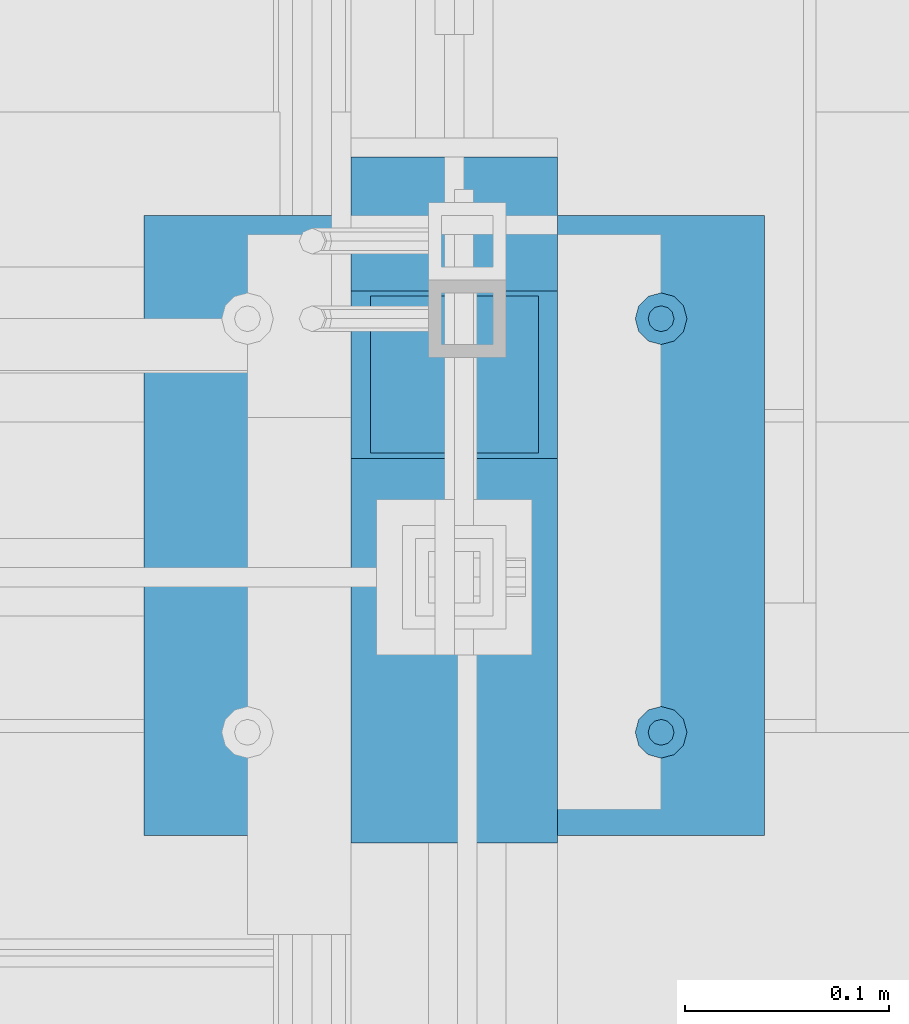
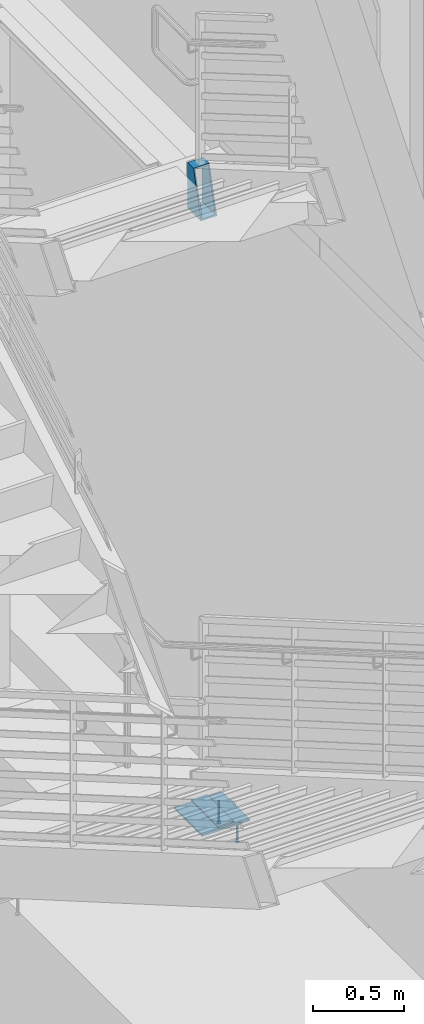
# One storey, part 875 of 1179: 5 beams, 3 elements without a shape of their own.
"""IFC2X3 building model written with IfcOpenShell, lengths in millimetres."""

from ifc_helpers import new_model, si_unit, frame, origin_with_axes, place, context, subcontext, project, spatial, faceted_brep, material, type_object, element, aggregate, save


model = new_model("IFC2X3")

# Units and contexts
model_context = context("Model", 3, precision=1e-05, world=origin_with_axes())
body_context = subcontext(model_context, "Body", "Model", "MODEL_VIEW")
ifc_project = project(units=[si_unit("LENGTHUNIT", "METRE", prefix="MILLI"), si_unit("AREAUNIT", "SQUARE_METRE"), si_unit("VOLUMEUNIT", "CUBIC_METRE"), si_unit("MASSUNIT", "GRAM", prefix="KILO"), si_unit("TIMEUNIT", "SECOND"), si_unit("PLANEANGLEUNIT", "RADIAN"), si_unit("SOLIDANGLEUNIT", "STERADIAN"), si_unit("THERMODYNAMICTEMPERATUREUNIT", "DEGREE_CELSIUS"), si_unit("LUMINOUSINTENSITYUNIT", "LUMEN")], contexts=[model_context])

# Site, building, storey
site_placement = place(None, origin_with_axes())
site = spatial("IfcSite", under=ifc_project, at=site_placement, CompositionType="ELEMENT")
building_placement = place(site_placement, origin_with_axes())
building = spatial("IfcBuilding", under=site, at=building_placement, Name="Undefined", CompositionType="ELEMENT")
storey_placement = place(building_placement, origin_with_axes())
storey = spatial("IfcBuildingStorey", under=building, at=storey_placement, Name="Undefined", CompositionType="ELEMENT", Elevation=0.0)

# Assembly, beams
assembly_1_placement = place(storey_placement, origin_with_axes())
assembly_1 = element("IfcElementAssembly", 1, at=assembly_1_placement, inside=storey, Name="EMBED", AssemblyPlace="NOTDEFINED", PredefinedType="RIGID_FRAME")
ifc_material_1 = material(Name="STEEL/A108")
beam_type_1 = type_object("IfcBeamType", Name="STUD_1/2-DIA", PredefinedType="NOTDEFINED")
beam_1_placement = place(assembly_1_placement, frame((-152.399999997227, 35242.5000000001, -12.6999996742202), z_axis=(0.0, 1.0, 0.0), x_axis=(0.0, 0.0, -1.0)))
beam_1 = element("IfcBeam", 2, at=beam_1_placement, type_object=beam_type_1, material=ifc_material_1, Name="STUD", ObjectType="STUD_1/2-DIA", context=body_context, shape_type="Brep", body=[
    faceted_brep([(0.0, -3.1800000667572, 5.5), (0.0, -5.5, 3.1800000667572), (141.732, -5.5, 3.1800000667572), (141.732, -3.1800000667572, 5.5), (0.0, -6.34999999999854, 0.0), (141.732, -6.34999990463257, 0.0), (0.0, -5.5, -3.1800000667572), (141.732, -5.5, -3.1800000667572), (0.0, -3.1800000667572, -5.5), (141.732, -3.1800000667572, -5.5), (0.0, 0.0, -6.34999999999991), (141.732, 0.0, -6.34999990463257), (0.0, 3.1800000667572, -5.5), (141.732, 3.1800000667572, -5.5), (0.0, 5.5, -3.1800000667572), (141.732, 5.5, -3.1800000667572), (0.0, 6.34999999999854, 0.0), (141.732, 6.34999990463257, 0.0), (0.0, 5.5, 3.1800000667572), (141.732, 5.5, 3.1800000667572), (0.0, 3.1800000667572, 5.5), (141.732, 3.1800000667572, 5.5), (0.0, 0.0, 6.34999999999991), (141.732, 0.0, 6.34999990463257), (144.78, -10.9899997711182, 6.34999990463257), (144.78, -6.34000015258789, 10.9899997711182), (144.78, -12.6999998092651, 0.0), (144.78, -10.9899997711182, -6.34999990463257), (144.78, -6.34000015258789, -10.9899997711182), (144.78, 0.0, -12.6899995803833), (144.78, 6.34000015258789, -10.9899997711182), (144.78, 10.9899997711182, -6.34999990463257), (144.78, 12.6999998092651, 0.0), (144.78, 10.9899997711182, 6.34999990463257), (144.78, 6.34000015258789, 10.9899997711182), (144.78, 0.0, 12.6899995803833), (152.4, -10.9899997711182, 6.34999990463257), (152.4, -6.34000015258789, 10.9899997711182), (152.4, -12.6999998092651, 0.0), (152.4, -10.9899997711182, -6.34999990463257), (152.4, -6.34000015258789, -10.9899997711182), (152.4, 0.0, -12.6899995803833), (152.4, 6.34000015258789, -10.9899997711182), (152.4, 10.9899997711182, -6.34999990463257), (152.4, 12.6999998092651, 0.0), (152.4, 10.9899997711182, 6.34999990463257), (152.4, 6.34000015258789, 10.9899997711182), (152.4, 0.0, 12.6899995803833)], [[[0, 1, 2, 3]], [[1, 4, 5, 2]], [[4, 6, 7, 5]], [[6, 8, 9, 7]], [[8, 10, 11, 9]], [[10, 12, 13, 11]], [[12, 14, 15, 13]], [[14, 16, 17, 15]], [[16, 18, 19, 17]], [[18, 20, 21, 19]], [[20, 22, 23, 21]], [[22, 0, 3, 23]], [[22, 20, 18, 16, 14, 12, 10, 8, 6, 4, 1, 0]], [[3, 2, 24, 25]], [[2, 5, 26, 24]], [[5, 7, 27, 26]], [[7, 9, 28, 27]], [[9, 11, 29, 28]], [[11, 13, 30, 29]], [[13, 15, 31, 30]], [[15, 17, 32, 31]], [[17, 19, 33, 32]], [[19, 21, 34, 33]], [[21, 23, 35, 34]], [[23, 3, 25, 35]], [[25, 24, 36, 37]], [[24, 26, 38, 36]], [[26, 27, 39, 38]], [[27, 28, 40, 39]], [[28, 29, 41, 40]], [[29, 30, 42, 41]], [[30, 31, 43, 42]], [[31, 32, 44, 43]], [[32, 33, 45, 44]], [[33, 34, 46, 45]], [[34, 35, 47, 46]], [[35, 25, 37, 47]], [[38, 39, 40, 41, 42, 43, 44, 45, 46, 47, 37, 36]]]),
])
beam_2_placement = place(assembly_1_placement, frame((-152.399999997227, 35039.3000000001, -12.6999996742202), z_axis=(0.0, 1.0, 0.0), x_axis=(0.0, 0.0, -1.0)))
beam_2 = element("IfcBeam", 3, at=beam_2_placement, type_object=beam_type_1, material=ifc_material_1, Name="STUD", ObjectType="STUD_1/2-DIA", context=body_context, shape_type="Brep", body=[
    faceted_brep([(0.0, -3.1800000667572, 5.5), (0.0, -5.5, 3.1800000667572), (141.732, -5.5, 3.1800000667572), (141.732, -3.1800000667572, 5.5), (0.0, -6.34999999999854, 0.0), (141.732, -6.34999990463257, 0.0), (0.0, -5.5, -3.1800000667572), (141.732, -5.5, -3.1800000667572), (0.0, -3.1800000667572, -5.5), (141.732, -3.1800000667572, -5.5), (0.0, 0.0, -6.34999999999991), (141.732, 0.0, -6.34999990463257), (0.0, 3.1800000667572, -5.5), (141.732, 3.1800000667572, -5.5), (0.0, 5.5, -3.1800000667572), (141.732, 5.5, -3.1800000667572), (0.0, 6.34999999999854, 0.0), (141.732, 6.34999990463257, 0.0), (0.0, 5.5, 3.1800000667572), (141.732, 5.5, 3.1800000667572), (0.0, 3.1800000667572, 5.5), (141.732, 3.1800000667572, 5.5), (0.0, 0.0, 6.34999999999991), (141.732, 0.0, 6.34999990463257), (144.78, -10.9899997711182, 6.34999990463257), (144.78, -6.34000015258789, 10.9899997711182), (144.78, -12.6999998092651, 0.0), (144.78, -10.9899997711182, -6.34999990463257), (144.78, -6.34000015258789, -10.9899997711182), (144.78, 0.0, -12.6899995803833), (144.78, 6.34000015258789, -10.9899997711182), (144.78, 10.9899997711182, -6.34999990463257), (144.78, 12.6999998092651, 0.0), (144.78, 10.9899997711182, 6.34999990463257), (144.78, 6.34000015258789, 10.9899997711182), (144.78, 0.0, 12.6899995803833), (152.4, -10.9899997711182, 6.34999990463257), (152.4, -6.34000015258789, 10.9899997711182), (152.4, -12.6999998092651, 0.0), (152.4, -10.9899997711182, -6.34999990463257), (152.4, -6.34000015258789, -10.9899997711182), (152.4, 0.0, -12.6899995803833), (152.4, 6.34000015258789, -10.9899997711182), (152.4, 10.9899997711182, -6.34999990463257), (152.4, 12.6999998092651, 0.0), (152.4, 10.9899997711182, 6.34999990463257), (152.4, 6.34000015258789, 10.9899997711182), (152.4, 0.0, 12.6899995803833)], [[[0, 1, 2, 3]], [[1, 4, 5, 2]], [[4, 6, 7, 5]], [[6, 8, 9, 7]], [[8, 10, 11, 9]], [[10, 12, 13, 11]], [[12, 14, 15, 13]], [[14, 16, 17, 15]], [[16, 18, 19, 17]], [[18, 20, 21, 19]], [[20, 22, 23, 21]], [[22, 0, 3, 23]], [[22, 20, 18, 16, 14, 12, 10, 8, 6, 4, 1, 0]], [[3, 2, 24, 25]], [[2, 5, 26, 24]], [[5, 7, 27, 26]], [[7, 9, 28, 27]], [[9, 11, 29, 28]], [[11, 13, 30, 29]], [[13, 15, 31, 30]], [[15, 17, 32, 31]], [[17, 19, 33, 32]], [[19, 21, 34, 33]], [[21, 23, 35, 34]], [[23, 3, 25, 35]], [[25, 24, 36, 37]], [[24, 26, 38, 36]], [[26, 27, 39, 38]], [[27, 28, 40, 39]], [[28, 29, 41, 40]], [[29, 30, 42, 41]], [[30, 31, 43, 42]], [[31, 32, 44, 43]], [[32, 33, 45, 44]], [[33, 34, 46, 45]], [[34, 35, 47, 46]], [[35, 25, 37, 47]], [[38, 39, 40, 41, 42, 43, 44, 45, 46, 47, 37, 36]]]),
])

# Assembly, beam
assembly_2_placement = place(storey_placement, origin_with_axes())
assembly_2 = element("IfcElementAssembly", 4, at=assembly_2_placement, inside=storey, Name="STRINGER", AssemblyPlace="NOTDEFINED", PredefinedType="RIGID_FRAME")
ifc_material_2 = material(Name="STEEL/A36")
beam_type_2 = type_object("IfcBeamType", PredefinedType="NOTDEFINED")
beam_3_placement = place(assembly_2_placement, frame((-254.000000000423, 34985.0008605265, 17.7800015461292), z_axis=(-1.0, 0.0, 0.0), x_axis=(0.0, 1.0, 0.0)))
beam_3 = element("IfcBeam", 5, at=beam_3_placement, type_object=beam_type_2, material=ifc_material_2, Name="PLATE", context=body_context, shape_type="Brep", body=[
    faceted_brep([(0.0, 4.76249999999982, -50.7999999999993), (0.0, 4.76249999999982, 50.7999999999993), (298.774139809131, 4.76250000000038, 50.8), (298.774139809131, 4.76250000000038, -50.8), (0.0, -4.76249999999982, 50.7999999999993), (298.774139809109, -4.7624999999996, 50.8), (0.0, -4.76249999999982, -50.7999999999993), (298.774139809109, -4.7624999999996, -50.8)], [[[0, 1, 2, 3]], [[1, 4, 5, 2]], [[4, 6, 7, 5]], [[6, 0, 3, 7]], [[5, 7, 3, 2]], [[6, 4, 1, 0]]]),
])
aggregate(assembly_2, [beam_3])

assembly_3_placement = place(storey_placement, origin_with_axes())
assembly_3 = element("IfcElementAssembly", 6, at=assembly_3_placement, inside=storey, Name="STRINGER", AssemblyPlace="NOTDEFINED", PredefinedType="RIGID_FRAME")
ifc_material_3 = material()
beam_type_3 = type_object("IfcBeamType", Name="HSS12X4X3/8", PredefinedType="NOTDEFINED")
beam_4_placement = place(assembly_3_placement, frame((-253.999999998667, 35256.2337355151, 4133.84999890174), z_axis=(0.0, 0.0, 1.0), x_axis=(0.0, 1.0, 0.0)))
beam_4 = element("IfcBeam", 7, at=beam_4_placement, type_object=beam_type_3, material=ifc_material_3, Name="STRINGER", ObjectType="HSS12X4X3/8", context=body_context, shape_type="Brep", body=[
    faceted_brep([(-79.8273428607608, 41.2750000000015, -142.874999999865), (-79.8273428607608, -41.2750000000015, -142.874999999865), (65.6412644876327, -41.275, -142.875), (65.6412644876327, 41.275, -142.875), (-2.57507558227371, -41.2750000000015, 142.874999999935), (65.6412644876327, -41.275, 142.875), (-2.57507558227371, 41.2750000000015, 142.874999999935), (65.6412644876327, 41.275, 142.875), (-82.4024182638459, 50.8000000000002, -152.4), (0.0, 50.8000000000029, 152.4), (65.6412644876327, 50.8, 152.4), (65.6412644876327, 50.8, -152.4), (0.0, -50.8000000000029, 152.4), (65.6412644876327, -50.8, 152.4), (-82.4024182638459, -50.8000000000002, -152.4), (65.6412644876327, -50.8, -152.4)], [[[0, 1, 2, 3]], [[1, 4, 5, 2]], [[4, 6, 7, 5]], [[6, 0, 3, 7]], [[8, 9, 10, 11]], [[9, 12, 13, 10]], [[12, 14, 15, 13]], [[14, 8, 11, 15]], [[13, 15, 11, 10], [5, 7, 3, 2]], [[14, 12, 9, 8], [6, 4, 1, 0]]]),
])
aggregate(assembly_3, [beam_4])

# Beam
beam_type_4 = type_object("IfcBeamType", PredefinedType="NOTDEFINED")
beam_5_placement = place(assembly_1_placement, frame((-101.599999997227, 35140.9, -6.35000000000009), z_axis=(0.0, 1.0, 0.0), x_axis=(-1.0, 0.0, 0.0)))
beam_5 = element("IfcBeam", 8, at=beam_5_placement, type_object=beam_type_4, material=ifc_material_2, Name="EMBED", context=body_context, shape_type="Brep", body=[
    faceted_brep([(0.0, 6.35, -152.400000000001), (0.0, 6.34999999999854, 152.400000000001), (304.799999999999, 6.35, 152.400000000001), (304.799999999999, 6.35, -152.400000000001), (0.0, -6.34999999999854, 152.400000000001), (304.799999999999, -6.35, 152.400000000001), (0.0, -6.35, -152.400000000001), (304.799999999999, -6.35, -152.400000000001)], [[[0, 1, 2, 3]], [[1, 4, 5, 2]], [[4, 6, 7, 5]], [[6, 0, 3, 7]], [[5, 7, 3, 2]], [[6, 4, 1, 0]]]),
])

aggregate(assembly_1, [beam_1, beam_2, beam_5])

save(model, "model.ifc")
